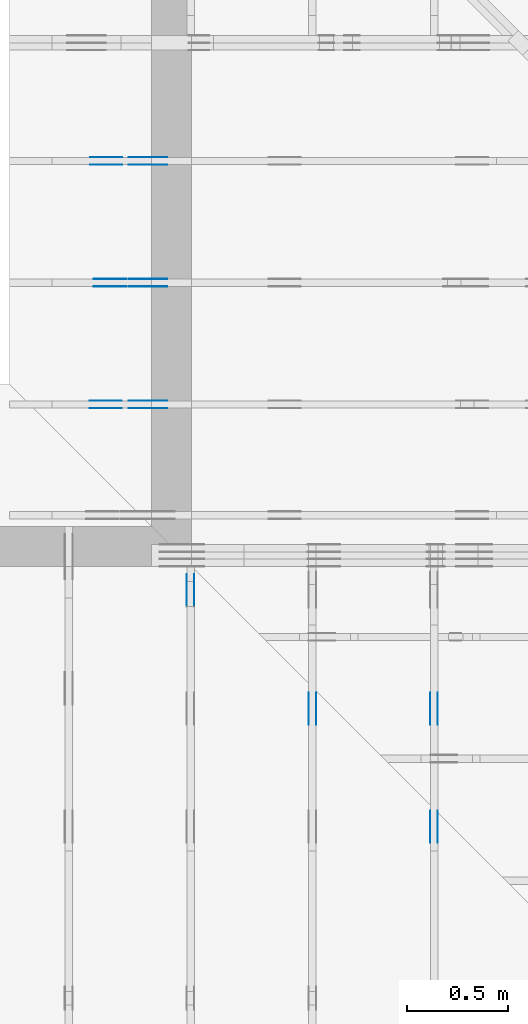
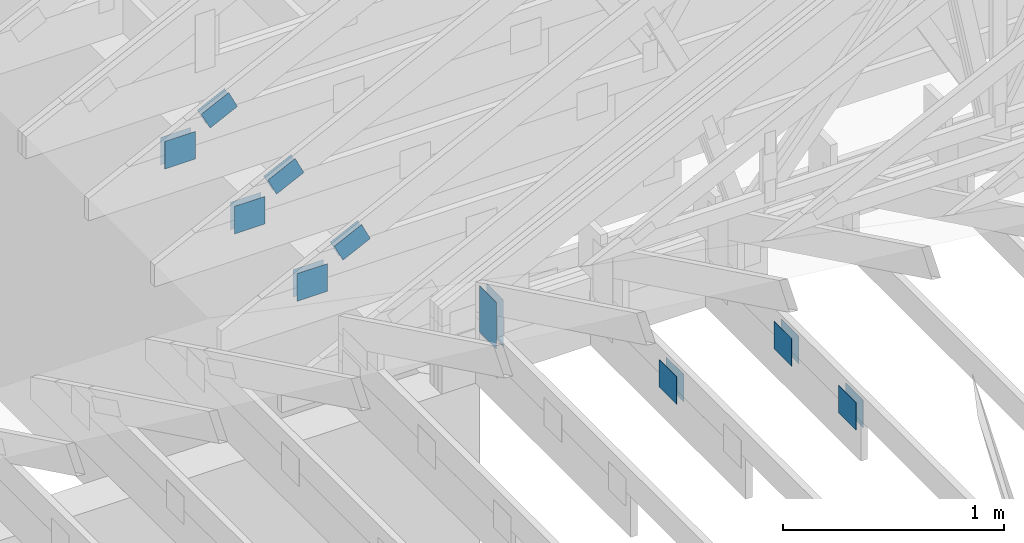
# One storey, part 98 of 159: 20 plates, 6 elements without a shape of their own.
"""IFC2X3 building model written with IfcOpenShell, lengths in millimetres."""

from ifc_helpers import new_model, si_unit, frame, origin, origin_with_axes, origin_2d, place, context, project, spatial, faceted_brep, element, aggregate, save


model = new_model("IFC2X3")

# Units and contexts
model_context = context("Model", 3, precision=1e-05, world=origin())
plan_context = context("Plan", 2, precision=1e-05, world=origin_2d())
ifc_project = project(units=[si_unit("LENGTHUNIT", "METRE", prefix="MILLI"), si_unit("AREAUNIT", "SQUARE_METRE"), si_unit("VOLUMEUNIT", "CUBIC_METRE"), si_unit("SOLIDANGLEUNIT", "STERADIAN"), si_unit("PLANEANGLEUNIT", "RADIAN"), si_unit("MASSUNIT", "GRAM"), si_unit("TIMEUNIT", "SECOND"), si_unit("THERMODYNAMICTEMPERATUREUNIT", "DEGREE_CELSIUS"), si_unit("LUMINOUSINTENSITYUNIT", "LUMEN")], contexts=[model_context, plan_context])

# Site, building, storey
site_placement = place(None, origin_with_axes())
site = spatial("IfcSite", under=ifc_project, at=site_placement, CompositionType="ELEMENT")
building_placement = place(site_placement, origin_with_axes())
building = spatial("IfcBuilding", under=site, at=building_placement, Name="Plan 1", CompositionType="ELEMENT")
storey_placement = place(building_placement, origin_with_axes())
storey = spatial("IfcBuildingStorey", under=building, at=storey_placement, Name="Etasje 1", CompositionType="ELEMENT", Elevation=0.0)

# Assembly, plates
assembly_1_placement = place(storey_placement, frame((19200.01266310149, 9617.999978540158, 1.1021457184401395e-15), z_axis=(1.2246063538223773e-16, 1.0, 6.123031769111886e-17), x_axis=(-1.0, 1.2246063538223773e-16, 0.0)))
assembly_1 = element("IfcElementAssembly", 1, at=assembly_1_placement, inside=storey, Name="V12 (104)", AssemblyPlace="FACTORY", PredefinedType="TRUSS")
plate_1_placement = place(assembly_1_placement, frame((8610.597668641334, 382.43740333568803, 0.0), z_axis=(0.0, 0.0, 1.0), x_axis=(-0.8987940462991673, 0.4383711467890769, 0.0)))
plate_1 = element("IfcPlate", 2, at=plate_1_placement, Name="GNT100S 103x159", context=model_context, shape_type="Brep", body=[
    faceted_brep([(159.0000669164201, 103.00006850985756, 1.0), (0.00010902310077653965, 103.00006850985756, 1.0), (0.0, 2.8266765184525866e-05, 1.0), (158.99995789331842, 2.8266765184525866e-05, 1.0), (0.00010902310077653965, 103.00006850985756, 1.335103819243678e-20), (159.0000669164201, 103.00006850985756, 1.9471249220403124e-14), (158.99995789331842, 0.0, 1.947123586936482e-14), (0.0, 0.0, 0.0), (159.00037272487225, 0.00019972633614805693, 1.7883493332506108e-30), (159.00037272487225, 0.00019972633614811816, 1.0), (0.00037272487224981887, 0.00019972633617732502, 1.0), (0.00037272487224981887, 0.0001997263361772638, 4.513898307157584e-36), (159.00037272487225, 103.00019972633618, 0.0), (159.00037272487225, 103.00019972633618, 1.0), (159.00037272487225, 0.00019972633617726387, 1.0), (159.00037272487225, 0.00019972633617726387, 0.0), (0.00037272487224981887, 103.00019972633618, 0.0), (0.00037272487224981887, 103.00019972633618, 1.0), (159.00037272487225, 103.00019972633616, 1.0), (159.00037272487225, 103.00019972633616, -7.888609052210118e-31), (0.00037272487224981887, 0.00019972633617726387, 0.0), (0.00037272487224988013, 0.00019972633617726387, 1.0), (0.0003727248722624936, 103.00019972633618, 1.0), (0.0003727248722624323, 103.00019972633618, -7.723280003546626e-31)], [[[0, 1, 2, 3]], [[4, 5, 6, 7]], [[8, 9, 10, 11]], [[12, 13, 14, 15]], [[16, 17, 18, 19]], [[20, 21, 22, 23]]]),
])
plate_2_placement = place(assembly_1_placement, frame((8610.597668641334, 382.43740333568803, -37.0), z_axis=(0.0, 0.0, 1.0), x_axis=(-0.8987940462991673, 0.4383711467890769, 0.0)))
plate_2 = element("IfcPlate", 3, at=plate_2_placement, Name="GNT100S 103x159", context=model_context, shape_type="Brep", body=[
    faceted_brep([(159.0000669164201, 103.00006850985756, 1.0), (0.00010902310077653965, 103.00006850985756, 1.0), (0.0, 2.8266765184525866e-05, 1.0), (158.99995789331842, 2.8266765184525866e-05, 1.0), (0.00010902310077653965, 103.00006850985756, 1.335103819243678e-20), (159.0000669164201, 103.00006850985756, 1.9471249220403124e-14), (158.99995789331842, 0.0, 1.947123586936482e-14), (0.0, 0.0, 0.0), (159.00037272487225, 0.00019972633614805693, 1.7883493332506108e-30), (159.00037272487225, 0.00019972633614811816, 1.0), (0.00037272487224981887, 0.00019972633617732502, 1.0), (0.00037272487224981887, 0.0001997263361772638, 4.513898307157584e-36), (159.00037272487225, 103.00019972633618, 0.0), (159.00037272487225, 103.00019972633618, 1.0), (159.00037272487225, 0.00019972633617726387, 1.0), (159.00037272487225, 0.00019972633617726387, 0.0), (0.00037272487224981887, 103.00019972633618, 0.0), (0.00037272487224981887, 103.00019972633618, 1.0), (159.00037272487225, 103.00019972633616, 1.0), (159.00037272487225, 103.00019972633616, -7.888609052210118e-31), (0.00037272487224981887, 0.00019972633617726387, 0.0), (0.00037272487224988013, 0.00019972633617726387, 1.0), (0.0003727248722624936, 103.00019972633618, 1.0), (0.0003727248722624323, 103.00019972633618, -7.723280003546626e-31)], [[[0, 1, 2, 3]], [[4, 5, 6, 7]], [[8, 9, 10, 11]], [[12, 13, 14, 15]], [[16, 17, 18, 19]], [[20, 21, 22, 23]]]),
])
plate_3_placement = place(assembly_1_placement, frame((8804.4111328125, 299.0000000000006, 0.0), z_axis=(0.0, 0.0, 1.0), x_axis=(-1.0, 1.2246063538223773e-16, 0.0)))
plate_3 = element("IfcPlate", 4, at=plate_3_placement, Name="GNT100S 152x159", context=model_context, shape_type="Brep", body=[
    faceted_brep([(159.0, 152.00000000000063, 1.0), (0.0, 152.00000000000063, 1.0), (0.0, 6.252776074688882e-13, 1.0), (159.0, 6.252776074688882e-13, 1.0), (0.0, 152.00000000000063, 0.0), (159.0, 152.00000000000063, 1.9471241025775798e-14), (159.0, 6.252776074688882e-13, 1.9471241025775798e-14), (0.0, 6.252776074688882e-13, 0.0), (159.0004161546858, -2.920693798251456e-14, 1.7883500914541728e-30), (159.0004161546858, -2.914570766482344e-14, 1.0), (0.0004161546858085785, 6.115387384025674e-17, 1.0), (0.0004161546858085785, -7.644385086212105e-20, 4.6806812738201824e-36), (159.0004161546858, 152.00000000000003, 0.0), (159.0004161546858, 152.00000000000003, 1.0), (159.0004161546858, 0.0, 1.0), (159.0004161546858, 0.0, 0.0), (0.0004161546858085785, 152.0, 0.0), (0.0004161546858085785, 152.0, 1.0), (159.0004161546858, 152.00000000000003, 1.0), (159.0004161546858, 152.00000000000003, 0.0), (0.0004161546858085785, 0.0, 0.0), (0.00041615468580863976, -7.498303609110687e-33, 1.0), (0.0004161546858272538, 152.0, 1.0), (0.0004161546858271925, 152.0, -1.1397412669640613e-30)], [[[0, 1, 2, 3]], [[4, 5, 6, 7]], [[8, 9, 10, 11]], [[12, 13, 14, 15]], [[16, 17, 18, 19]], [[20, 21, 22, 23]]]),
])
plate_4_placement = place(assembly_1_placement, frame((8804.4111328125, 299.0000000000006, -37.0), z_axis=(0.0, 0.0, 1.0), x_axis=(-1.0, 1.2246063538223773e-16, 0.0)))
plate_4 = element("IfcPlate", 5, at=plate_4_placement, Name="GNT100S 152x159", context=model_context, shape_type="Brep", body=[
    faceted_brep([(159.0, 152.00000000000063, 1.0), (0.0, 152.00000000000063, 1.0), (0.0, 6.252776074688882e-13, 1.0), (159.0, 6.252776074688882e-13, 1.0), (0.0, 152.00000000000063, 0.0), (159.0, 152.00000000000063, 1.9471241025775798e-14), (159.0, 6.252776074688882e-13, 1.9471241025775798e-14), (0.0, 6.252776074688882e-13, 0.0), (159.0004161546858, -2.920693798251456e-14, 1.7883500914541728e-30), (159.0004161546858, -2.914570766482344e-14, 1.0), (0.0004161546858085785, 6.115387384025674e-17, 1.0), (0.0004161546858085785, -7.644385086212105e-20, 4.6806812738201824e-36), (159.0004161546858, 152.00000000000003, 0.0), (159.0004161546858, 152.00000000000003, 1.0), (159.0004161546858, 0.0, 1.0), (159.0004161546858, 0.0, 0.0), (0.0004161546858085785, 152.0, 0.0), (0.0004161546858085785, 152.0, 1.0), (159.0004161546858, 152.00000000000003, 1.0), (159.0004161546858, 152.00000000000003, 0.0), (0.0004161546858085785, 0.0, 0.0), (0.00041615468580863976, -7.498303609110687e-33, 1.0), (0.0004161546858272538, 152.0, 1.0), (0.0004161546858271925, 152.0, -1.1397412669640613e-30)], [[[0, 1, 2, 3]], [[4, 5, 6, 7]], [[8, 9, 10, 11]], [[12, 13, 14, 15]], [[16, 17, 18, 19]], [[20, 21, 22, 23]]]),
])
aggregate(assembly_1, [plate_1, plate_2, plate_3, plate_4])

assembly_2_placement = place(storey_placement, frame((12075.022261404752, -699.9989301294854, 4.558494966049043e-13), z_axis=(-1.0, 1.836909530733566e-16, 6.123031769111886e-17), x_axis=(-1.836909530733566e-16, -1.0, 0.0)))
assembly_2 = element("IfcElementAssembly", 6, at=assembly_2_placement, inside=storey, Name="T5 (98)", AssemblyPlace="FACTORY", PredefinedType="TRUSS")
plate_5_placement = place(assembly_2_placement, frame((-8880.4990234375, 147.0, 0.0), z_axis=(0.0, 0.0, 1.0), x_axis=(1.0, 0.0, 0.0)))
plate_5 = element("IfcPlate", 7, at=plate_5_placement, Name="GNT100S 152x159", context=model_context, shape_type="Brep", body=[
    faceted_brep([(159.0, 152.0, 1.0), (0.0, 152.0, 1.0), (0.0, 0.0, 1.0), (159.0, 0.0, 1.0), (0.0, 152.0, 0.0), (159.0, 152.0, 1.9471241025775798e-14), (159.0, 0.0, 1.9471241025775798e-14), (0.0, 0.0, 0.0), (159.00009331759065, -2.9206878680260863e-14, 1.7883464603583392e-30), (159.00009331759065, -2.9145648362569744e-14, 1.0), (9.331759065389633e-05, 6.121317609395314e-17, 1.0), (9.331759065389633e-05, -1.714159716572357e-20, 1.0495854401904369e-36), (159.00009331759065, 152.0, 0.0), (159.00009331759065, 152.0, 1.0), (159.00009331759065, 0.0, 1.0), (159.00009331759065, 0.0, 0.0), (9.331759065389633e-05, 152.0, 0.0), (9.331759065389633e-05, 152.0, 1.0), (159.00009331759065, 152.0, 1.0), (159.00009331759065, 152.0, 0.0), (9.331759065389633e-05, 0.0, 0.0), (9.331759065395756e-05, -7.498303609110687e-33, 1.0), (9.331759067257158e-05, 152.0, 1.0), (9.331759067251035e-05, 152.0, -1.1397420192804459e-30)], [[[0, 1, 2, 3]], [[4, 5, 6, 7]], [[8, 9, 10, 11]], [[12, 13, 14, 15]], [[16, 17, 18, 19]], [[20, 21, 22, 23]]]),
])
plate_6_placement = place(assembly_2_placement, frame((-8880.4990234375, 147.0, -37.0), z_axis=(0.0, 0.0, 1.0), x_axis=(1.0, 0.0, 0.0)))
plate_6 = element("IfcPlate", 8, at=plate_6_placement, Name="GNT100S 152x159", context=model_context, shape_type="Brep", body=[
    faceted_brep([(159.0, 152.0, 1.0), (0.0, 152.0, 1.0), (0.0, 0.0, 1.0), (159.0, 0.0, 1.0), (0.0, 152.0, 0.0), (159.0, 152.0, 1.9471241025775798e-14), (159.0, 0.0, 1.9471241025775798e-14), (0.0, 0.0, 0.0), (159.00009331759065, -2.9206878680260863e-14, 1.7883464603583392e-30), (159.00009331759065, -2.9145648362569744e-14, 1.0), (9.331759065389633e-05, 6.121317609395314e-17, 1.0), (9.331759065389633e-05, -1.714159716572357e-20, 1.0495854401904369e-36), (159.00009331759065, 152.0, 0.0), (159.00009331759065, 152.0, 1.0), (159.00009331759065, 0.0, 1.0), (159.00009331759065, 0.0, 0.0), (9.331759065389633e-05, 152.0, 0.0), (9.331759065389633e-05, 152.0, 1.0), (159.00009331759065, 152.0, 1.0), (159.00009331759065, 152.0, 0.0), (9.331759065389633e-05, 0.0, 0.0), (9.331759065395756e-05, -7.498303609110687e-33, 1.0), (9.331759067257158e-05, 152.0, 1.0), (9.331759067251035e-05, 152.0, -1.1397420192804459e-30)], [[[0, 1, 2, 3]], [[4, 5, 6, 7]], [[8, 9, 10, 11]], [[12, 13, 14, 15]], [[16, 17, 18, 19]], [[20, 21, 22, 23]]]),
])
plate_7_placement = place(assembly_2_placement, frame((-8139.998930119909, 299.0, 0.0), z_axis=(0.0, 0.0, 1.0), x_axis=(-1.0, 1.2246063538223773e-16, 0.0)))
plate_7 = element("IfcPlate", 9, at=plate_7_placement, Name="GNT100S 152x159", context=model_context, shape_type="Brep", body=[
    faceted_brep([(159.00009331759065, 151.99999999999997, 1.0), (9.331759065389633e-05, 151.99999999999997, 1.0), (9.331759065389633e-05, 0.0, 1.0), (159.00009331759065, 0.0, 1.0), (9.331759065389633e-05, 151.99999999999997, 1.1427731443815714e-20), (159.00009331759065, 151.99999999999997, 1.9471252453507242e-14), (159.00009331759065, 0.0, 1.9471252453507242e-14), (9.331759065389633e-05, 0.0, 1.1427731443815714e-20), (159.0, -2.92068615386637e-14, 1.788345410772899e-30), (159.0, -2.914563122097258e-14, 1.0), (1.1247455413666031e-32, 6.123031769111886e-17, 1.0), (0.0, 0.0, 0.0), (159.0, 152.0, 0.0), (159.0, 152.0, 1.0), (159.0, 0.0, 1.0), (159.0, 0.0, 0.0), (0.0, 151.99999999999997, 0.0), (0.0, 151.99999999999997, 1.0), (159.0, 152.0, 1.0), (159.0, 152.0, 0.0), (0.0, 0.0, 0.0), (6.123031769111886e-17, -7.498303609110687e-33, 1.0), (1.867524689579125e-14, 151.99999999999997, 1.0), (1.861401657810013e-14, 151.99999999999997, -1.1397421485848243e-30)], [[[0, 1, 2, 3]], [[4, 5, 6, 7]], [[8, 9, 10, 11]], [[12, 13, 14, 15]], [[16, 17, 18, 19]], [[20, 21, 22, 23]]]),
])
plate_8_placement = place(assembly_2_placement, frame((-8139.998930119909, 299.0, -37.0), z_axis=(0.0, 0.0, 1.0), x_axis=(-1.0, 1.2246063538223773e-16, 0.0)))
plate_8 = element("IfcPlate", 10, at=plate_8_placement, Name="GNT100S 152x159", context=model_context, shape_type="Brep", body=[
    faceted_brep([(159.00009331759065, 151.99999999999997, 1.0), (9.331759065389633e-05, 151.99999999999997, 1.0), (9.331759065389633e-05, 0.0, 1.0), (159.00009331759065, 0.0, 1.0), (9.331759065389633e-05, 151.99999999999997, 1.1427731443815714e-20), (159.00009331759065, 151.99999999999997, 1.9471252453507242e-14), (159.00009331759065, 0.0, 1.9471252453507242e-14), (9.331759065389633e-05, 0.0, 1.1427731443815714e-20), (159.0, -2.92068615386637e-14, 1.788345410772899e-30), (159.0, -2.914563122097258e-14, 1.0), (1.1247455413666031e-32, 6.123031769111886e-17, 1.0), (0.0, 0.0, 0.0), (159.0, 152.0, 0.0), (159.0, 152.0, 1.0), (159.0, 0.0, 1.0), (159.0, 0.0, 0.0), (0.0, 151.99999999999997, 0.0), (0.0, 151.99999999999997, 1.0), (159.0, 152.0, 1.0), (159.0, 152.0, 0.0), (0.0, 0.0, 0.0), (6.123031769111886e-17, -7.498303609110687e-33, 1.0), (1.867524689579125e-14, 151.99999999999997, 1.0), (1.861401657810013e-14, 151.99999999999997, -1.1397421485848243e-30)], [[[0, 1, 2, 3]], [[4, 5, 6, 7]], [[8, 9, 10, 11]], [[12, 13, 14, 15]], [[16, 17, 18, 19]], [[20, 21, 22, 23]]]),
])
aggregate(assembly_2, [plate_5, plate_6, plate_7, plate_8])

assembly_3_placement = place(storey_placement, frame((11475.022261404752, -699.9989301294845, 1.1021457184401395e-15), z_axis=(-1.0, 1.836909530733566e-16, 6.123031769111886e-17), x_axis=(-1.836909530733566e-16, -1.0, 0.0)))
assembly_3 = element("IfcElementAssembly", 11, at=assembly_3_placement, inside=storey, Name="T5 (97)", AssemblyPlace="FACTORY", PredefinedType="TRUSS")
plate_9_placement = place(assembly_3_placement, frame((-8880.4990234375, 147.0, 0.0), z_axis=(0.0, 0.0, 1.0), x_axis=(1.0, 0.0, 0.0)))
plate_9 = element("IfcPlate", 12, at=plate_9_placement, Name="GNT100S 152x159", context=model_context, shape_type="Brep", body=[
    faceted_brep([(159.0, 152.0, 1.0), (0.0, 152.0, 1.0), (0.0, 0.0, 1.0), (159.0, 0.0, 1.0), (0.0, 152.0, 0.0), (159.0, 152.0, 1.9471241025775798e-14), (159.0, 0.0, 1.9471241025775798e-14), (0.0, 0.0, 0.0), (159.00009331759065, -2.9206878680260863e-14, 1.7883464603583392e-30), (159.00009331759065, -2.9145648362569744e-14, 1.0), (9.331759065389633e-05, 6.121317609395314e-17, 1.0), (9.331759065389633e-05, -1.714159716572357e-20, 1.0495854401904369e-36), (159.00009331759065, 152.0, 0.0), (159.00009331759065, 152.0, 1.0), (159.00009331759065, 0.0, 1.0), (159.00009331759065, 0.0, 0.0), (9.331759065389633e-05, 152.0, 0.0), (9.331759065389633e-05, 152.0, 1.0), (159.00009331759065, 152.0, 1.0), (159.00009331759065, 152.0, 0.0), (9.331759065389633e-05, 0.0, 0.0), (9.331759065395756e-05, -7.498303609110687e-33, 1.0), (9.331759067257158e-05, 152.0, 1.0), (9.331759067251035e-05, 152.0, -1.1397420192804459e-30)], [[[0, 1, 2, 3]], [[4, 5, 6, 7]], [[8, 9, 10, 11]], [[12, 13, 14, 15]], [[16, 17, 18, 19]], [[20, 21, 22, 23]]]),
])
plate_10_placement = place(assembly_3_placement, frame((-8880.4990234375, 147.0, -37.0), z_axis=(0.0, 0.0, 1.0), x_axis=(1.0, 0.0, 0.0)))
plate_10 = element("IfcPlate", 13, at=plate_10_placement, Name="GNT100S 152x159", context=model_context, shape_type="Brep", body=[
    faceted_brep([(159.0, 152.0, 1.0), (0.0, 152.0, 1.0), (0.0, 0.0, 1.0), (159.0, 0.0, 1.0), (0.0, 152.0, 0.0), (159.0, 152.0, 1.9471241025775798e-14), (159.0, 0.0, 1.9471241025775798e-14), (0.0, 0.0, 0.0), (159.00009331759065, -2.9206878680260863e-14, 1.7883464603583392e-30), (159.00009331759065, -2.9145648362569744e-14, 1.0), (9.331759065389633e-05, 6.121317609395314e-17, 1.0), (9.331759065389633e-05, -1.714159716572357e-20, 1.0495854401904369e-36), (159.00009331759065, 152.0, 0.0), (159.00009331759065, 152.0, 1.0), (159.00009331759065, 0.0, 1.0), (159.00009331759065, 0.0, 0.0), (9.331759065389633e-05, 152.0, 0.0), (9.331759065389633e-05, 152.0, 1.0), (159.00009331759065, 152.0, 1.0), (159.00009331759065, 152.0, 0.0), (9.331759065389633e-05, 0.0, 0.0), (9.331759065395756e-05, -7.498303609110687e-33, 1.0), (9.331759067257158e-05, 152.0, 1.0), (9.331759067251035e-05, 152.0, -1.1397420192804459e-30)], [[[0, 1, 2, 3]], [[4, 5, 6, 7]], [[8, 9, 10, 11]], [[12, 13, 14, 15]], [[16, 17, 18, 19]], [[20, 21, 22, 23]]]),
])
aggregate(assembly_3, [plate_9, plate_10])

assembly_4_placement = place(storey_placement, frame((10875.02226140475, -699.9989301294845, 1.1021457184401395e-15), z_axis=(-1.0, 1.836909530733566e-16, 6.123031769111886e-17), x_axis=(-1.836909530733566e-16, -1.0, 0.0)))
assembly_4 = element("IfcElementAssembly", 14, at=assembly_4_placement, inside=storey, Name="T4 (96)", AssemblyPlace="FACTORY", PredefinedType="TRUSS")
plate_11_placement = place(assembly_4_placement, frame((-9310.706937860665, 304.0262036964527, 0.0), z_axis=(0.0, 0.0, 1.0), x_axis=(-2.6082967437366517e-12, 1.0, 0.0)))
plate_11 = element("IfcPlate", 15, at=plate_11_placement, Name="GNT100S 152x258", context=model_context, shape_type="Brep", body=[
    faceted_brep([(257.999980385975, 152.00009338933523, 1.0), (1.090355311816893e-05, 152.00009338933523, 1.0), (1.0903156692165794e-05, 9.338933523395099e-05, 1.0), (257.99998038557857, 9.338933523395099e-05, 1.0), (1.090355311816893e-05, 152.00009338933523, 1.3352560427749465e-21), (257.999980385975, 152.00009338933523, 3.159484152667137e-14), (257.99998038557857, 9.338866220787168e-05, 3.159484152662282e-14), (1.0903156692165794e-05, 9.338866220787168e-05, 1.3352074961947205e-21), (258.00000000000006, -4.739226589292601e-14, 2.9018434967258366e-30), (258.00000000000006, -4.7331035575234894e-14, 1.0), (5.684341886080802e-14, 6.123031769110842e-17, 1.0), (5.684341886080802e-14, -1.0441621786489838e-29, 6.393438191972809e-46), (258.00000000000006, 152.0, 0.0), (258.00000000000006, 152.0, 1.0), (258.00000000000006, 0.0, 1.0), (258.00000000000006, 0.0, 0.0), (0.0, 152.0, 0.0), (-3.7491518045553436e-33, 152.0, 1.0), (258.00000000000006, 151.99999999999997, 1.0), (258.00000000000006, 151.99999999999997, -1.5777218104420236e-30), (5.684341886080802e-14, 0.0, 0.0), (5.690464917849913e-14, 1.96934197932066e-32, 1.0), (8.01710585938975e-15, 152.0, 1.0), (7.955875541698632e-15, 152.0, -4.871407869292096e-31)], [[[0, 1, 2, 3]], [[4, 5, 6, 7]], [[8, 9, 10, 11]], [[12, 13, 14, 15]], [[16, 17, 18, 19]], [[20, 21, 22, 23]]]),
])
plate_12_placement = place(assembly_4_placement, frame((-9310.706937860665, 304.0262036964527, -37.0), z_axis=(0.0, 0.0, 1.0), x_axis=(-2.6082967437366517e-12, 1.0, 0.0)))
plate_12 = element("IfcPlate", 16, at=plate_12_placement, Name="GNT100S 152x258", context=model_context, shape_type="Brep", body=[
    faceted_brep([(257.999980385975, 152.00009338933523, 1.0), (1.090355311816893e-05, 152.00009338933523, 1.0), (1.0903156692165794e-05, 9.338933523395099e-05, 1.0), (257.99998038557857, 9.338933523395099e-05, 1.0), (1.090355311816893e-05, 152.00009338933523, 1.3352560427749465e-21), (257.999980385975, 152.00009338933523, 3.159484152667137e-14), (257.99998038557857, 9.338866220787168e-05, 3.159484152662282e-14), (1.0903156692165794e-05, 9.338866220787168e-05, 1.3352074961947205e-21), (258.00000000000006, -4.739226589292601e-14, 2.9018434967258366e-30), (258.00000000000006, -4.7331035575234894e-14, 1.0), (5.684341886080802e-14, 6.123031769110842e-17, 1.0), (5.684341886080802e-14, -1.0441621786489838e-29, 6.393438191972809e-46), (258.00000000000006, 152.0, 0.0), (258.00000000000006, 152.0, 1.0), (258.00000000000006, 0.0, 1.0), (258.00000000000006, 0.0, 0.0), (0.0, 152.0, 0.0), (-3.7491518045553436e-33, 152.0, 1.0), (258.00000000000006, 151.99999999999997, 1.0), (258.00000000000006, 151.99999999999997, -1.5777218104420236e-30), (5.684341886080802e-14, 0.0, 0.0), (5.690464917849913e-14, 1.96934197932066e-32, 1.0), (8.01710585938975e-15, 152.0, 1.0), (7.955875541698632e-15, 152.0, -4.871407869292096e-31)], [[[0, 1, 2, 3]], [[4, 5, 6, 7]], [[8, 9, 10, 11]], [[12, 13, 14, 15]], [[16, 17, 18, 19]], [[20, 21, 22, 23]]]),
])
aggregate(assembly_4, [plate_11, plate_12])

assembly_5_placement = place(storey_placement, frame((19200.01266310149, 10817.999978540158, 1.1021457184401395e-15), z_axis=(1.2246063538223773e-16, 1.0, 6.123031769111886e-17), x_axis=(-1.0, 1.2246063538223773e-16, 0.0)))
assembly_5 = element("IfcElementAssembly", 17, at=assembly_5_placement, inside=storey, Name="V10 (59)", AssemblyPlace="FACTORY", PredefinedType="TRUSS")
plate_13_placement = place(assembly_5_placement, frame((8610.597668641334, 382.4374033356871, 0.0), z_axis=(0.0, 0.0, 1.0), x_axis=(-0.8987940462991675, 0.4383711467890765, 0.0)))
plate_13 = element("IfcPlate", 18, at=plate_13_placement, Name="GNT100S 103x159", context=model_context, shape_type="Brep", body=[
    faceted_brep([(159.00006691642102, 103.0000685098571, 1.0), (0.00010902310168603435, 103.0000685098571, 1.0), (0.0, 2.8266764275031164e-05, 1.0), (158.99995789331933, 2.8266764275031164e-05, 1.0), (0.00010902310168603435, 103.0000685098571, 1.335103830381408e-20), (159.00006691642102, 103.0000685098571, 1.9471249220403234e-14), (158.99995789331933, 0.0, 1.947123586936493e-14), (0.0, 0.0, 0.0), (159.000372726543, 0.0001997271511343578, -3.0517879647912495e-30), (159.000372726543, 0.00019972715113441902, 1.0), (0.00037272654299158603, 0.0001997271501750833, 1.0), (0.00037272654299158603, 0.00019972715017502207, -7.52316384526264e-36), (159.000372726543, 103.00019972715108, -5.522026336547083e-29), (159.000372726543, 103.00019972715108, 1.0), (159.000372726543, 0.00019972715108451666, 1.0), (159.000372726543, 0.00019972715108451666, 0.0), (0.00037272654390108073, 103.00019972715108, 0.0), (0.00037272654390108073, 103.00019972715108, 1.0), (159.0003727265439, 103.00019972715107, 1.0), (159.0003727265439, 103.00019972715107, -7.888609052210118e-31), (0.00037272654299158603, 0.000199727150175022, -3.009265538105056e-36), (0.0003727265429916473, 0.000199727150175022, 1.0), (0.0003727265439190845, 103.00019972715108, 1.0), (0.00037272654391902325, 103.00019972715108, -1.09862868118247e-30)], [[[0, 1, 2, 3]], [[4, 5, 6, 7]], [[8, 9, 10, 11]], [[12, 13, 14, 15]], [[16, 17, 18, 19]], [[20, 21, 22, 23]]]),
])
plate_14_placement = place(assembly_5_placement, frame((8610.597668641334, 382.4374033356871, -37.0), z_axis=(0.0, 0.0, 1.0), x_axis=(-0.8987940462991675, 0.4383711467890765, 0.0)))
plate_14 = element("IfcPlate", 19, at=plate_14_placement, Name="GNT100S 103x159", context=model_context, shape_type="Brep", body=[
    faceted_brep([(159.00006691642102, 103.0000685098571, 1.0), (0.00010902310168603435, 103.0000685098571, 1.0), (0.0, 2.8266764275031164e-05, 1.0), (158.99995789331933, 2.8266764275031164e-05, 1.0), (0.00010902310168603435, 103.0000685098571, 1.335103830381408e-20), (159.00006691642102, 103.0000685098571, 1.9471249220403234e-14), (158.99995789331933, 0.0, 1.947123586936493e-14), (0.0, 0.0, 0.0), (159.000372726543, 0.0001997271511343578, -3.0517879647912495e-30), (159.000372726543, 0.00019972715113441902, 1.0), (0.00037272654299158603, 0.0001997271501750833, 1.0), (0.00037272654299158603, 0.00019972715017502207, -7.52316384526264e-36), (159.000372726543, 103.00019972715108, -5.522026336547083e-29), (159.000372726543, 103.00019972715108, 1.0), (159.000372726543, 0.00019972715108451666, 1.0), (159.000372726543, 0.00019972715108451666, 0.0), (0.00037272654390108073, 103.00019972715108, 0.0), (0.00037272654390108073, 103.00019972715108, 1.0), (159.0003727265439, 103.00019972715107, 1.0), (159.0003727265439, 103.00019972715107, -7.888609052210118e-31), (0.00037272654299158603, 0.000199727150175022, -3.009265538105056e-36), (0.0003727265429916473, 0.000199727150175022, 1.0), (0.0003727265439190845, 103.00019972715108, 1.0), (0.00037272654391902325, 103.00019972715108, -1.09862868118247e-30)], [[[0, 1, 2, 3]], [[4, 5, 6, 7]], [[8, 9, 10, 11]], [[12, 13, 14, 15]], [[16, 17, 18, 19]], [[20, 21, 22, 23]]]),
])
plate_15_placement = place(assembly_5_placement, frame((8801.609375000033, 299.0, 0.0), z_axis=(0.0, 0.0, 1.0), x_axis=(-1.0, 2.1239710294371217e-13, 0.0)))
plate_15 = element("IfcPlate", 20, at=plate_15_placement, Name="GNT100S 152x159", context=model_context, shape_type="Brep", body=[
    faceted_brep([(159.0, 151.99999999999997, 1.0), (0.0, 151.99999999999997, 1.0), (3.2741809263825417e-11, 0.0, 1.0), (159.00000000003274, 0.0, 1.0), (0.0, 151.99999999999997, 0.0), (159.0, 151.99999999999997, 1.9471241025775798e-14), (159.00000000003274, 3.376499080331996e-11, 1.947124102577981e-14), (3.2741809263825417e-11, 3.376499080331996e-11, 4.009582766012098e-27), (159.00041615391456, 8.169244089295504e-10, 1.788350091444467e-30), (159.00041615391456, 8.169244701598681e-10, 1.0), (0.0004161539145570714, 8.169536770214068e-10, 1.0), (0.0004161539145570714, 8.169536157910891e-10, 4.680671568180496e-36), (159.00041615391456, 152.00000000081693, 0.0), (159.00041615391456, 152.00000000081693, 1.0), (159.00041615391456, 8.169536158675328e-10, 1.0), (159.00041615391456, 8.169536158675328e-10, 0.0), (0.0004161539145570714, 152.00000000081693, 0.0), (0.0004161539145570714, 152.00000000081693, 1.0), (159.00041615391456, 152.00000000081693, 1.0), (159.00041615391456, 152.00000000081693, 0.0), (0.0004161539145570714, 8.169536158675328e-10, 0.0), (0.00041615391455713266, 8.169536158675328e-10, 1.0), (0.0004161539145757467, 152.00000000081693, 1.0), (0.0004161539145756854, 152.00000000081693, -1.1397412669640613e-30)], [[[0, 1, 2, 3]], [[4, 5, 6, 7]], [[8, 9, 10, 11]], [[12, 13, 14, 15]], [[16, 17, 18, 19]], [[20, 21, 22, 23]]]),
])
plate_16_placement = place(assembly_5_placement, frame((8801.609375000033, 299.0, -37.0), z_axis=(0.0, 0.0, 1.0), x_axis=(-1.0, 2.1239710294371217e-13, 0.0)))
plate_16 = element("IfcPlate", 21, at=plate_16_placement, Name="GNT100S 152x159", context=model_context, shape_type="Brep", body=[
    faceted_brep([(159.0, 151.99999999999997, 1.0), (0.0, 151.99999999999997, 1.0), (3.2741809263825417e-11, 0.0, 1.0), (159.00000000003274, 0.0, 1.0), (0.0, 151.99999999999997, 0.0), (159.0, 151.99999999999997, 1.9471241025775798e-14), (159.00000000003274, 3.376499080331996e-11, 1.947124102577981e-14), (3.2741809263825417e-11, 3.376499080331996e-11, 4.009582766012098e-27), (159.00041615391456, 8.169244089295504e-10, 1.788350091444467e-30), (159.00041615391456, 8.169244701598681e-10, 1.0), (0.0004161539145570714, 8.169536770214068e-10, 1.0), (0.0004161539145570714, 8.169536157910891e-10, 4.680671568180496e-36), (159.00041615391456, 152.00000000081693, 0.0), (159.00041615391456, 152.00000000081693, 1.0), (159.00041615391456, 8.169536158675328e-10, 1.0), (159.00041615391456, 8.169536158675328e-10, 0.0), (0.0004161539145570714, 152.00000000081693, 0.0), (0.0004161539145570714, 152.00000000081693, 1.0), (159.00041615391456, 152.00000000081693, 1.0), (159.00041615391456, 152.00000000081693, 0.0), (0.0004161539145570714, 8.169536158675328e-10, 0.0), (0.00041615391455713266, 8.169536158675328e-10, 1.0), (0.0004161539145757467, 152.00000000081693, 1.0), (0.0004161539145756854, 152.00000000081693, -1.1397412669640613e-30)], [[[0, 1, 2, 3]], [[4, 5, 6, 7]], [[8, 9, 10, 11]], [[12, 13, 14, 15]], [[16, 17, 18, 19]], [[20, 21, 22, 23]]]),
])
aggregate(assembly_5, [plate_13, plate_14, plate_15, plate_16])

assembly_6_placement = place(storey_placement, frame((19200.01266310149, 10217.999978540158, 1.1021457184401395e-15), z_axis=(1.2246063538223773e-16, 1.0, 6.123031769111886e-17), x_axis=(-1.0, 1.2246063538223773e-16, 0.0)))
assembly_6 = element("IfcElementAssembly", 22, at=assembly_6_placement, inside=storey, Name="V11 (60)", AssemblyPlace="FACTORY", PredefinedType="TRUSS")
plate_17_placement = place(assembly_6_placement, frame((8610.597668641334, 382.4374033356871, 0.0), z_axis=(0.0, 0.0, 1.0), x_axis=(-0.8987940462991675, 0.4383711467890765, 0.0)))
plate_17 = element("IfcPlate", 23, at=plate_17_placement, Name="GNT100S 103x159", context=model_context, shape_type="Brep", body=[
    faceted_brep([(159.00006691642102, 103.0000685098571, 1.0), (0.00010902310168603435, 103.0000685098571, 1.0), (0.0, 2.8266764275031164e-05, 1.0), (158.99995789331933, 2.8266764275031164e-05, 1.0), (0.00010902310168603435, 103.0000685098571, 1.335103830381408e-20), (159.00006691642102, 103.0000685098571, 1.9471249220403234e-14), (158.99995789331933, 0.0, 1.947123586936493e-14), (0.0, 0.0, 0.0), (159.00037272486952, 0.00019972633341957283, 1.7883493332506108e-30), (159.00037272486952, 0.00019972633341963406, 1.0), (0.00037272486952133477, 0.00019972633344884092, 1.0), (0.00037272486952133477, 0.0001997263334487797, 4.513898307157584e-36), (159.00037272486952, 103.0001997263339, 0.0), (159.00037272486952, 103.0001997263339, 1.0), (159.00037272486952, 0.00019972633344877977, 1.0), (159.00037272486952, 0.00019972633344877977, 0.0), (0.00037272487043082947, 103.00019972633436, 0.0), (0.00037272487043082947, 103.00019972633436, 1.0), (159.0003727248695, 103.00019972633389, 1.0), (159.0003727248695, 103.00019972633389, -7.888609052210118e-31), (0.00037272486952133477, 0.0001997263334487798, -3.009265538105056e-36), (0.000372724869521396, 0.0001997263334487798, 1.0), (0.00037272487044883324, 103.00019972633436, 1.0), (0.000372724870448772, 103.00019972633436, -1.09862868118247e-30)], [[[0, 1, 2, 3]], [[4, 5, 6, 7]], [[8, 9, 10, 11]], [[12, 13, 14, 15]], [[16, 17, 18, 19]], [[20, 21, 22, 23]]]),
])
plate_18_placement = place(assembly_6_placement, frame((8610.597668641334, 382.4374033356871, -37.0), z_axis=(0.0, 0.0, 1.0), x_axis=(-0.8987940462991675, 0.4383711467890765, 0.0)))
plate_18 = element("IfcPlate", 24, at=plate_18_placement, Name="GNT100S 103x159", context=model_context, shape_type="Brep", body=[
    faceted_brep([(159.00006691642102, 103.0000685098571, 1.0), (0.00010902310168603435, 103.0000685098571, 1.0), (0.0, 2.8266764275031164e-05, 1.0), (158.99995789331933, 2.8266764275031164e-05, 1.0), (0.00010902310168603435, 103.0000685098571, 1.335103830381408e-20), (159.00006691642102, 103.0000685098571, 1.9471249220403234e-14), (158.99995789331933, 0.0, 1.947123586936493e-14), (0.0, 0.0, 0.0), (159.00037272486952, 0.00019972633341957283, 1.7883493332506108e-30), (159.00037272486952, 0.00019972633341963406, 1.0), (0.00037272486952133477, 0.00019972633344884092, 1.0), (0.00037272486952133477, 0.0001997263334487797, 4.513898307157584e-36), (159.00037272486952, 103.0001997263339, 0.0), (159.00037272486952, 103.0001997263339, 1.0), (159.00037272486952, 0.00019972633344877977, 1.0), (159.00037272486952, 0.00019972633344877977, 0.0), (0.00037272487043082947, 103.00019972633436, 0.0), (0.00037272487043082947, 103.00019972633436, 1.0), (159.0003727248695, 103.00019972633389, 1.0), (159.0003727248695, 103.00019972633389, -7.888609052210118e-31), (0.00037272486952133477, 0.0001997263334487798, -3.009265538105056e-36), (0.000372724869521396, 0.0001997263334487798, 1.0), (0.00037272487044883324, 103.00019972633436, 1.0), (0.000372724870448772, 103.00019972633436, -1.09862868118247e-30)], [[[0, 1, 2, 3]], [[4, 5, 6, 7]], [[8, 9, 10, 11]], [[12, 13, 14, 15]], [[16, 17, 18, 19]], [[20, 21, 22, 23]]]),
])
plate_19_placement = place(assembly_6_placement, frame((8783.396484375, 299.0000000000007, 0.0), z_axis=(0.0, 0.0, 1.0), x_axis=(-1.0, 1.2246063538223773e-16, 0.0)))
plate_19 = element("IfcPlate", 25, at=plate_19_placement, Name="GNT100S 152x159", context=model_context, shape_type="Brep", body=[
    faceted_brep([(159.0, 152.00000000000068, 1.0), (0.0, 152.00000000000068, 1.0), (0.0, 6.821210263296962e-13, 1.0), (159.0, 6.821210263296962e-13, 1.0), (0.0, 152.00000000000068, 0.0), (159.0, 152.00000000000068, 1.9471241025775798e-14), (159.0, 6.821210263296962e-13, 1.9471241025775798e-14), (0.0, 6.821210263296962e-13, 0.0), (159.00041615654845, -2.920693798285671e-14, 1.7883500914751226e-30), (159.00041615654845, -2.9145707665165594e-14, 1.0), (0.00041615654845372774, 6.115387349810568e-17, 1.0), (0.00041615654845372774, -7.644419301318375e-20, 4.68070222383845e-36), (159.00041615654845, 152.00000000000003, 0.0), (159.00041615654845, 152.00000000000003, 1.0), (159.00041615654845, 0.0, 1.0), (159.00041615654845, 0.0, 0.0), (0.00041615654845372774, 152.0, 0.0), (0.00041615654845372774, 152.0, 1.0), (159.00041615654845, 152.00000000000003, 1.0), (159.00041615654845, 152.00000000000003, 0.0), (0.00041615654845372774, 0.0, 0.0), (0.000416156548453789, -7.498303609110687e-33, 1.0), (0.000416156548472403, 152.0, 1.0), (0.00041615654847234175, 152.0, -1.1397412669640613e-30)], [[[0, 1, 2, 3]], [[4, 5, 6, 7]], [[8, 9, 10, 11]], [[12, 13, 14, 15]], [[16, 17, 18, 19]], [[20, 21, 22, 23]]]),
])
plate_20_placement = place(assembly_6_placement, frame((8783.396484375, 299.0000000000007, -37.0), z_axis=(0.0, 0.0, 1.0), x_axis=(-1.0, 1.2246063538223773e-16, 0.0)))
plate_20 = element("IfcPlate", 26, at=plate_20_placement, Name="GNT100S 152x159", context=model_context, shape_type="Brep", body=[
    faceted_brep([(159.0, 152.00000000000068, 1.0), (0.0, 152.00000000000068, 1.0), (0.0, 6.821210263296962e-13, 1.0), (159.0, 6.821210263296962e-13, 1.0), (0.0, 152.00000000000068, 0.0), (159.0, 152.00000000000068, 1.9471241025775798e-14), (159.0, 6.821210263296962e-13, 1.9471241025775798e-14), (0.0, 6.821210263296962e-13, 0.0), (159.00041615654845, -2.920693798285671e-14, 1.7883500914751226e-30), (159.00041615654845, -2.9145707665165594e-14, 1.0), (0.00041615654845372774, 6.115387349810568e-17, 1.0), (0.00041615654845372774, -7.644419301318375e-20, 4.68070222383845e-36), (159.00041615654845, 152.00000000000003, 0.0), (159.00041615654845, 152.00000000000003, 1.0), (159.00041615654845, 0.0, 1.0), (159.00041615654845, 0.0, 0.0), (0.00041615654845372774, 152.0, 0.0), (0.00041615654845372774, 152.0, 1.0), (159.00041615654845, 152.00000000000003, 1.0), (159.00041615654845, 152.00000000000003, 0.0), (0.00041615654845372774, 0.0, 0.0), (0.000416156548453789, -7.498303609110687e-33, 1.0), (0.000416156548472403, 152.0, 1.0), (0.00041615654847234175, 152.0, -1.1397412669640613e-30)], [[[0, 1, 2, 3]], [[4, 5, 6, 7]], [[8, 9, 10, 11]], [[12, 13, 14, 15]], [[16, 17, 18, 19]], [[20, 21, 22, 23]]]),
])
aggregate(assembly_6, [plate_17, plate_18, plate_19, plate_20])

save(model, "model.ifc")
